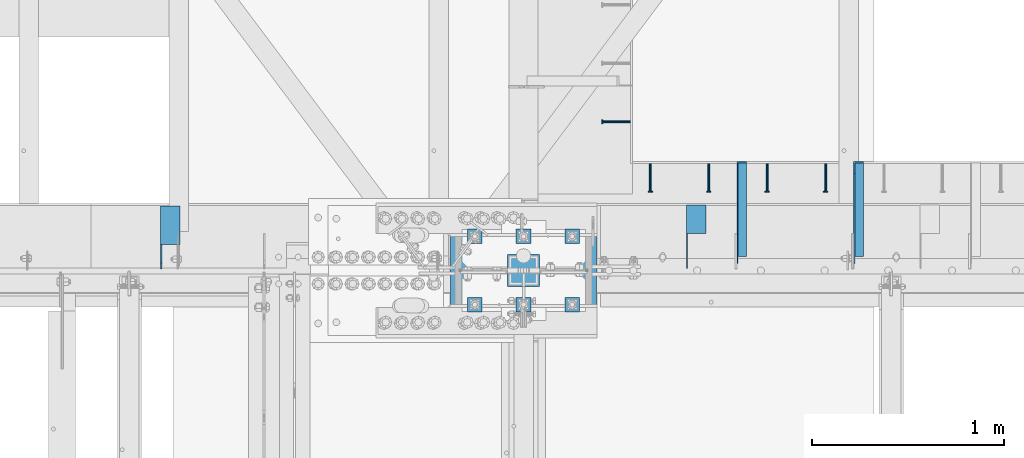
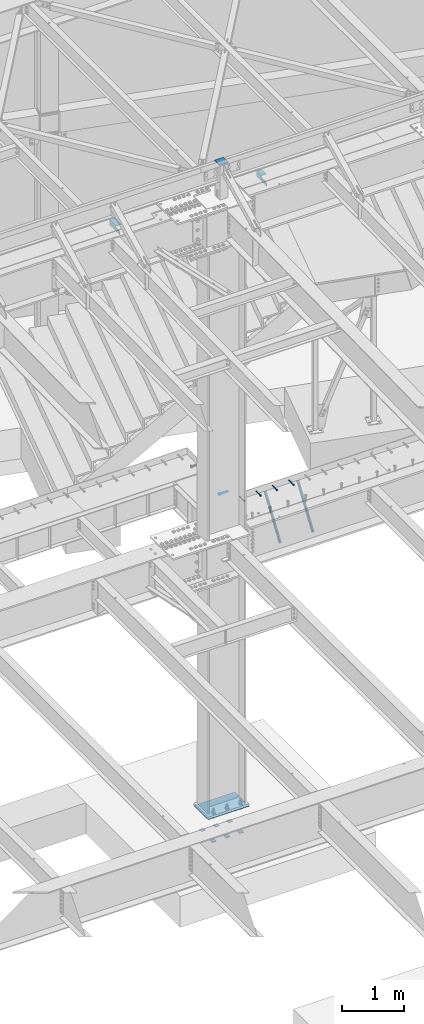
# One storey, part 1354 of 1763: 15 beams, 2 members, 10 elements without a shape of their own.
"""IFC2X3 building model written with IfcOpenShell, lengths in millimetres."""

from ifc_helpers import new_model, si_unit, frame, origin_with_axes, place, context, subcontext, project, spatial, faceted_brep, material, type_object, element, aggregate, save


model = new_model("IFC2X3")

# Units and contexts
model_context = context("Model", 3, precision=1e-05, world=origin_with_axes())
body_context = subcontext(model_context, "Body", "Model", "MODEL_VIEW")
ifc_project = project(units=[si_unit("LENGTHUNIT", "METRE", prefix="MILLI"), si_unit("AREAUNIT", "SQUARE_METRE"), si_unit("VOLUMEUNIT", "CUBIC_METRE"), si_unit("MASSUNIT", "GRAM", prefix="KILO"), si_unit("TIMEUNIT", "SECOND"), si_unit("PLANEANGLEUNIT", "RADIAN"), si_unit("SOLIDANGLEUNIT", "STERADIAN"), si_unit("THERMODYNAMICTEMPERATUREUNIT", "DEGREE_CELSIUS"), si_unit("LUMINOUSINTENSITYUNIT", "LUMEN")], contexts=[model_context])

# Site, building, storey
site_placement = place(None, origin_with_axes())
site = spatial("IfcSite", under=ifc_project, at=site_placement, CompositionType="ELEMENT")
building_placement = place(site_placement, origin_with_axes())
building = spatial("IfcBuilding", under=site, at=building_placement, Name="Undefined", CompositionType="ELEMENT")
storey_placement = place(building_placement, origin_with_axes())
storey = spatial("IfcBuildingStorey", under=building, at=storey_placement, Name="Undefined", CompositionType="ELEMENT", Elevation=0.0)

# Assembly, beam
assembly_1_placement = place(storey_placement, origin_with_axes())
assembly_1 = element("IfcElementAssembly", 1, at=assembly_1_placement, inside=storey, Name="HEADED STUD ANCHOR", AssemblyPlace="NOTDEFINED", PredefinedType="RIGID_FRAME")
ifc_material_1 = material(Name="STEEL/A108")
beam_type_1 = type_object("IfcBeamType", PredefinedType="NOTDEFINED")
beam_1_placement = place(assembly_1_placement, frame((-34391.0368708663, 52897.0884999161, 5264.15), z_axis=(0.0, 0.0, 1.0), x_axis=(-1.0, 0.0, 0.0)))
beam_1 = element("IfcBeam", 2, at=beam_1_placement, type_object=beam_type_1, material=ifc_material_1, Name="HEADED STUD ANCHOR", context=body_context, shape_type="Brep", body=[
    faceted_brep([(0.0, -3.1800000667572, 5.5), (0.0, -5.5, 3.1800000667572), (141.732000000002, -5.5, 3.1800000667572), (141.732000000002, -3.1800000667572, 5.5), (0.0, -6.34999999999491, 1.45519152283669e-11), (141.732000000002, -6.34999990463257, 0.0), (0.0, -5.5, -3.1800000667572), (141.732000000002, -5.5, -3.1800000667572), (0.0, -3.1800000667572, -5.5), (141.732000000002, -3.1800000667572, -5.5), (0.0, 0.0, -6.34999990463257), (141.732000000002, 0.0, -6.34999990463257), (0.0, 3.1800000667572, -5.5), (141.732000000002, 3.1800000667572, -5.5), (0.0, 5.5, -3.1800000667572), (141.732000000002, 5.5, -3.1800000667572), (0.0, 6.34999999999491, -2.91038304567337e-11), (141.732000000002, 6.34999990463257, 0.0), (0.0, 5.5, 3.1800000667572), (141.732000000002, 5.5, 3.1800000667572), (0.0, 3.1800000667572, 5.5), (141.732000000002, 3.1800000667572, 5.5), (0.0, 0.0, 6.34999990463257), (141.732000000002, 0.0, 6.34999990463257), (144.780000000001, -10.9899997711182, 6.34999990463257), (144.780000000001, -6.34000015258789, 10.9899997711182), (144.780000000001, -12.6999998092651, 0.0), (144.780000000001, -10.9899997711182, -6.34999990463257), (144.780000000001, -6.34000015258789, -10.9899997711182), (144.780000000001, 0.0, -12.6899995803833), (144.780000000001, 6.34000015258789, -10.9899997711182), (144.780000000001, 10.9899997711182, -6.34999990463257), (144.780000000001, 12.6999998092651, 0.0), (144.780000000001, 10.9899997711182, 6.34999990463257), (144.780000000001, 6.34000015258789, 10.9899997711182), (144.780000000001, 0.0, 12.6899995803833), (152.400000000001, -10.9899997711182, 6.34999990463257), (152.400000000001, -6.34000015258789, 10.9899997711182), (152.400000000001, -12.6999998092651, 0.0), (152.400000000001, -10.9899997711182, -6.34999990463257), (152.400000000001, -6.34000015258789, -10.9899997711182), (152.400000000001, 0.0, -12.6899995803833), (152.400000000001, 6.34000015258789, -10.9899997711182), (152.400000000001, 10.9899997711182, -6.34999990463257), (152.400000000001, 12.6999998092651, 0.0), (152.400000000001, 10.9899997711182, 6.34999990463257), (152.400000000001, 6.34000015258789, 10.9899997711182), (152.400000000001, 0.0, 12.6899995803833)], [[[0, 1, 2, 3]], [[1, 4, 5, 2]], [[4, 6, 7, 5]], [[6, 8, 9, 7]], [[8, 10, 11, 9]], [[10, 12, 13, 11]], [[12, 14, 15, 13]], [[14, 16, 17, 15]], [[16, 18, 19, 17]], [[18, 20, 21, 19]], [[20, 22, 23, 21]], [[22, 0, 3, 23]], [[22, 20, 18, 16, 14, 12, 10, 8, 6, 4, 1, 0]], [[3, 2, 24, 25]], [[2, 5, 26, 24]], [[5, 7, 27, 26]], [[7, 9, 28, 27]], [[9, 11, 29, 28]], [[11, 13, 30, 29]], [[13, 15, 31, 30]], [[15, 17, 32, 31]], [[17, 19, 33, 32]], [[19, 21, 34, 33]], [[21, 23, 35, 34]], [[23, 3, 25, 35]], [[25, 24, 36, 37]], [[24, 26, 38, 36]], [[26, 27, 39, 38]], [[27, 28, 40, 39]], [[28, 29, 41, 40]], [[29, 30, 42, 41]], [[30, 31, 43, 42]], [[31, 32, 44, 43]], [[32, 33, 45, 44]], [[33, 34, 46, 45]], [[34, 35, 47, 46]], [[35, 25, 37, 47]], [[38, 39, 40, 41, 42, 43, 44, 45, 46, 47, 37, 36]]]),
])
aggregate(assembly_1, [beam_1])

assembly_2_placement = place(storey_placement, origin_with_axes())
assembly_2 = element("IfcElementAssembly", 3, at=assembly_2_placement, inside=storey, Name="HEADED STUD ANCHOR", AssemblyPlace="NOTDEFINED", PredefinedType="RIGID_FRAME")
beam_2_placement = place(assembly_2_placement, frame((-33373.8466486983, 52679.6000091552, 5264.23140606069), z_axis=(0.0, 0.0, 1.0), x_axis=(0.0, -1.0, 0.0)))
beam_2 = element("IfcBeam", 4, at=beam_2_placement, type_object=beam_type_1, material=ifc_material_1, Name="HEADED STUD ANCHOR", context=body_context, shape_type="Brep", body=[
    faceted_brep([(0.0, -3.1800000667572, 5.5), (0.0, -5.5, 3.1800000667572), (141.732000000002, -5.5, 3.1800000667572), (141.732000000002, -3.1800000667572, 5.5), (0.0, -6.34999999999491, 1.45519152283669e-11), (141.732000000002, -6.34999990463257, 0.0), (0.0, -5.5, -3.1800000667572), (141.732000000002, -5.5, -3.1800000667572), (0.0, -3.1800000667572, -5.5), (141.732000000002, -3.1800000667572, -5.5), (0.0, 0.0, -6.34999990463257), (141.732000000002, 0.0, -6.34999990463257), (0.0, 3.1800000667572, -5.5), (141.732000000002, 3.1800000667572, -5.5), (0.0, 5.5, -3.1800000667572), (141.732000000002, 5.5, -3.1800000667572), (0.0, 6.34999999999491, -2.91038304567337e-11), (141.732000000002, 6.34999990463257, 0.0), (0.0, 5.5, 3.1800000667572), (141.732000000002, 5.5, 3.1800000667572), (0.0, 3.1800000667572, 5.5), (141.732000000002, 3.1800000667572, 5.5), (0.0, 0.0, 6.34999990463257), (141.732000000002, 0.0, 6.34999990463257), (144.780000000001, -10.9899997711182, 6.34999990463257), (144.780000000001, -6.34000015258789, 10.9899997711182), (144.780000000001, -12.6999998092651, 0.0), (144.780000000001, -10.9899997711182, -6.34999990463257), (144.780000000001, -6.34000015258789, -10.9899997711182), (144.780000000001, 0.0, -12.6899995803833), (144.780000000001, 6.34000015258789, -10.9899997711182), (144.780000000001, 10.9899997711182, -6.34999990463257), (144.780000000001, 12.6999998092651, 0.0), (144.780000000001, 10.9899997711182, 6.34999990463257), (144.780000000001, 6.34000015258789, 10.9899997711182), (144.780000000001, 0.0, 12.6899995803833), (152.400000000001, -10.9899997711182, 6.34999990463257), (152.400000000001, -6.34000015258789, 10.9899997711182), (152.400000000001, -12.6999998092651, 0.0), (152.400000000001, -10.9899997711182, -6.34999990463257), (152.400000000001, -6.34000015258789, -10.9899997711182), (152.400000000001, 0.0, -12.6899995803833), (152.400000000001, 6.34000015258789, -10.9899997711182), (152.400000000001, 10.9899997711182, -6.34999990463257), (152.400000000001, 12.6999998092651, 0.0), (152.400000000001, 10.9899997711182, 6.34999990463257), (152.400000000001, 6.34000015258789, 10.9899997711182), (152.400000000001, 0.0, 12.6899995803833)], [[[0, 1, 2, 3]], [[1, 4, 5, 2]], [[4, 6, 7, 5]], [[6, 8, 9, 7]], [[8, 10, 11, 9]], [[10, 12, 13, 11]], [[12, 14, 15, 13]], [[14, 16, 17, 15]], [[16, 18, 19, 17]], [[18, 20, 21, 19]], [[20, 22, 23, 21]], [[22, 0, 3, 23]], [[22, 20, 18, 16, 14, 12, 10, 8, 6, 4, 1, 0]], [[3, 2, 24, 25]], [[2, 5, 26, 24]], [[5, 7, 27, 26]], [[7, 9, 28, 27]], [[9, 11, 29, 28]], [[11, 13, 30, 29]], [[13, 15, 31, 30]], [[15, 17, 32, 31]], [[17, 19, 33, 32]], [[19, 21, 34, 33]], [[21, 23, 35, 34]], [[23, 3, 25, 35]], [[25, 24, 36, 37]], [[24, 26, 38, 36]], [[26, 27, 39, 38]], [[27, 28, 40, 39]], [[28, 29, 41, 40]], [[29, 30, 42, 41]], [[30, 31, 43, 42]], [[31, 32, 44, 43]], [[32, 33, 45, 44]], [[33, 34, 46, 45]], [[34, 35, 47, 46]], [[35, 25, 37, 47]], [[38, 39, 40, 41, 42, 43, 44, 45, 46, 47, 37, 36]]]),
])
aggregate(assembly_2, [beam_2])

assembly_3_placement = place(storey_placement, origin_with_axes())
assembly_3 = element("IfcElementAssembly", 5, at=assembly_3_placement, inside=storey, Name="HEADED STUD ANCHOR", AssemblyPlace="NOTDEFINED", PredefinedType="RIGID_FRAME")
beam_3_placement = place(assembly_3_placement, frame((-33678.6466486983, 52679.6000091552, 5264.23140606069), z_axis=(0.0, 0.0, 1.0), x_axis=(0.0, -1.0, 0.0)))
beam_3 = element("IfcBeam", 6, at=beam_3_placement, type_object=beam_type_1, material=ifc_material_1, Name="HEADED STUD ANCHOR", context=body_context, shape_type="Brep", body=[
    faceted_brep([(0.0, -3.1800000667572, 5.5), (0.0, -5.5, 3.1800000667572), (141.732000000002, -5.5, 3.1800000667572), (141.732000000002, -3.1800000667572, 5.5), (0.0, -6.34999999999491, 1.45519152283669e-11), (141.732000000002, -6.34999990463257, 0.0), (0.0, -5.5, -3.1800000667572), (141.732000000002, -5.5, -3.1800000667572), (0.0, -3.1800000667572, -5.5), (141.732000000002, -3.1800000667572, -5.5), (0.0, 0.0, -6.34999990463257), (141.732000000002, 0.0, -6.34999990463257), (0.0, 3.1800000667572, -5.5), (141.732000000002, 3.1800000667572, -5.5), (0.0, 5.5, -3.1800000667572), (141.732000000002, 5.5, -3.1800000667572), (0.0, 6.34999999999491, -2.91038304567337e-11), (141.732000000002, 6.34999990463257, 0.0), (0.0, 5.5, 3.1800000667572), (141.732000000002, 5.5, 3.1800000667572), (0.0, 3.1800000667572, 5.5), (141.732000000002, 3.1800000667572, 5.5), (0.0, 0.0, 6.34999990463257), (141.732000000002, 0.0, 6.34999990463257), (144.780000000001, -10.9899997711182, 6.34999990463257), (144.780000000001, -6.34000015258789, 10.9899997711182), (144.780000000001, -12.6999998092651, 0.0), (144.780000000001, -10.9899997711182, -6.34999990463257), (144.780000000001, -6.34000015258789, -10.9899997711182), (144.780000000001, 0.0, -12.6899995803833), (144.780000000001, 6.34000015258789, -10.9899997711182), (144.780000000001, 10.9899997711182, -6.34999990463257), (144.780000000001, 12.6999998092651, 0.0), (144.780000000001, 10.9899997711182, 6.34999990463257), (144.780000000001, 6.34000015258789, 10.9899997711182), (144.780000000001, 0.0, 12.6899995803833), (152.400000000001, -10.9899997711182, 6.34999990463257), (152.400000000001, -6.34000015258789, 10.9899997711182), (152.400000000001, -12.6999998092651, 0.0), (152.400000000001, -10.9899997711182, -6.34999990463257), (152.400000000001, -6.34000015258789, -10.9899997711182), (152.400000000001, 0.0, -12.6899995803833), (152.400000000001, 6.34000015258789, -10.9899997711182), (152.400000000001, 10.9899997711182, -6.34999990463257), (152.400000000001, 12.6999998092651, 0.0), (152.400000000001, 10.9899997711182, 6.34999990463257), (152.400000000001, 6.34000015258789, 10.9899997711182), (152.400000000001, 0.0, 12.6899995803833)], [[[0, 1, 2, 3]], [[1, 4, 5, 2]], [[4, 6, 7, 5]], [[6, 8, 9, 7]], [[8, 10, 11, 9]], [[10, 12, 13, 11]], [[12, 14, 15, 13]], [[14, 16, 17, 15]], [[16, 18, 19, 17]], [[18, 20, 21, 19]], [[20, 22, 23, 21]], [[22, 0, 3, 23]], [[22, 20, 18, 16, 14, 12, 10, 8, 6, 4, 1, 0]], [[3, 2, 24, 25]], [[2, 5, 26, 24]], [[5, 7, 27, 26]], [[7, 9, 28, 27]], [[9, 11, 29, 28]], [[11, 13, 30, 29]], [[13, 15, 31, 30]], [[15, 17, 32, 31]], [[17, 19, 33, 32]], [[19, 21, 34, 33]], [[21, 23, 35, 34]], [[23, 3, 25, 35]], [[25, 24, 36, 37]], [[24, 26, 38, 36]], [[26, 27, 39, 38]], [[27, 28, 40, 39]], [[28, 29, 41, 40]], [[29, 30, 42, 41]], [[30, 31, 43, 42]], [[31, 32, 44, 43]], [[32, 33, 45, 44]], [[33, 34, 46, 45]], [[34, 35, 47, 46]], [[35, 25, 37, 47]], [[38, 39, 40, 41, 42, 43, 44, 45, 46, 47, 37, 36]]]),
])
aggregate(assembly_3, [beam_3])

assembly_4_placement = place(storey_placement, origin_with_axes())
assembly_4 = element("IfcElementAssembly", 7, at=assembly_4_placement, inside=storey, Name="HEADED STUD ANCHOR", AssemblyPlace="NOTDEFINED", PredefinedType="RIGID_FRAME")
beam_4_placement = place(assembly_4_placement, frame((-33983.4466486983, 52679.6000091552, 5264.23140606069), z_axis=(0.0, 0.0, 1.0), x_axis=(0.0, -1.0, 0.0)))
beam_4 = element("IfcBeam", 8, at=beam_4_placement, type_object=beam_type_1, material=ifc_material_1, Name="HEADED STUD ANCHOR", context=body_context, shape_type="Brep", body=[
    faceted_brep([(0.0, -3.1800000667572, 5.5), (0.0, -5.5, 3.1800000667572), (141.732000000002, -5.5, 3.1800000667572), (141.732000000002, -3.1800000667572, 5.5), (0.0, -6.34999999999491, 1.45519152283669e-11), (141.732000000002, -6.34999990463257, 0.0), (0.0, -5.5, -3.1800000667572), (141.732000000002, -5.5, -3.1800000667572), (0.0, -3.1800000667572, -5.5), (141.732000000002, -3.1800000667572, -5.5), (0.0, 0.0, -6.34999990463257), (141.732000000002, 0.0, -6.34999990463257), (0.0, 3.1800000667572, -5.5), (141.732000000002, 3.1800000667572, -5.5), (0.0, 5.5, -3.1800000667572), (141.732000000002, 5.5, -3.1800000667572), (0.0, 6.34999999999491, -2.91038304567337e-11), (141.732000000002, 6.34999990463257, 0.0), (0.0, 5.5, 3.1800000667572), (141.732000000002, 5.5, 3.1800000667572), (0.0, 3.1800000667572, 5.5), (141.732000000002, 3.1800000667572, 5.5), (0.0, 0.0, 6.34999990463257), (141.732000000002, 0.0, 6.34999990463257), (144.780000000001, -10.9899997711182, 6.34999990463257), (144.780000000001, -6.34000015258789, 10.9899997711182), (144.780000000001, -12.6999998092651, 0.0), (144.780000000001, -10.9899997711182, -6.34999990463257), (144.780000000001, -6.34000015258789, -10.9899997711182), (144.780000000001, 0.0, -12.6899995803833), (144.780000000001, 6.34000015258789, -10.9899997711182), (144.780000000001, 10.9899997711182, -6.34999990463257), (144.780000000001, 12.6999998092651, 0.0), (144.780000000001, 10.9899997711182, 6.34999990463257), (144.780000000001, 6.34000015258789, 10.9899997711182), (144.780000000001, 0.0, 12.6899995803833), (152.400000000001, -10.9899997711182, 6.34999990463257), (152.400000000001, -6.34000015258789, 10.9899997711182), (152.400000000001, -12.6999998092651, 0.0), (152.400000000001, -10.9899997711182, -6.34999990463257), (152.400000000001, -6.34000015258789, -10.9899997711182), (152.400000000001, 0.0, -12.6899995803833), (152.400000000001, 6.34000015258789, -10.9899997711182), (152.400000000001, 10.9899997711182, -6.34999990463257), (152.400000000001, 12.6999998092651, 0.0), (152.400000000001, 10.9899997711182, 6.34999990463257), (152.400000000001, 6.34000015258789, 10.9899997711182), (152.400000000001, 0.0, 12.6899995803833)], [[[0, 1, 2, 3]], [[1, 4, 5, 2]], [[4, 6, 7, 5]], [[6, 8, 9, 7]], [[8, 10, 11, 9]], [[10, 12, 13, 11]], [[12, 14, 15, 13]], [[14, 16, 17, 15]], [[16, 18, 19, 17]], [[18, 20, 21, 19]], [[20, 22, 23, 21]], [[22, 0, 3, 23]], [[22, 20, 18, 16, 14, 12, 10, 8, 6, 4, 1, 0]], [[3, 2, 24, 25]], [[2, 5, 26, 24]], [[5, 7, 27, 26]], [[7, 9, 28, 27]], [[9, 11, 29, 28]], [[11, 13, 30, 29]], [[13, 15, 31, 30]], [[15, 17, 32, 31]], [[17, 19, 33, 32]], [[19, 21, 34, 33]], [[21, 23, 35, 34]], [[23, 3, 25, 35]], [[25, 24, 36, 37]], [[24, 26, 38, 36]], [[26, 27, 39, 38]], [[27, 28, 40, 39]], [[28, 29, 41, 40]], [[29, 30, 42, 41]], [[30, 31, 43, 42]], [[31, 32, 44, 43]], [[32, 33, 45, 44]], [[33, 34, 46, 45]], [[34, 35, 47, 46]], [[35, 25, 37, 47]], [[38, 39, 40, 41, 42, 43, 44, 45, 46, 47, 37, 36]]]),
])
aggregate(assembly_4, [beam_4])

assembly_5_placement = place(storey_placement, origin_with_axes())
assembly_5 = element("IfcElementAssembly", 9, at=assembly_5_placement, inside=storey, Name="HEADED STUD ANCHOR", AssemblyPlace="NOTDEFINED", PredefinedType="RIGID_FRAME")
beam_5_placement = place(assembly_5_placement, frame((-34288.2466486983, 52679.6000091552, 5264.23140606069), z_axis=(0.0, 0.0, 1.0), x_axis=(0.0, -1.0, 0.0)))
beam_5 = element("IfcBeam", 10, at=beam_5_placement, type_object=beam_type_1, material=ifc_material_1, Name="HEADED STUD ANCHOR", context=body_context, shape_type="Brep", body=[
    faceted_brep([(0.0, -3.1800000667572, 5.5), (0.0, -5.5, 3.1800000667572), (141.732000000002, -5.5, 3.1800000667572), (141.732000000002, -3.1800000667572, 5.5), (0.0, -6.34999999999491, 1.45519152283669e-11), (141.732000000002, -6.34999990463257, 0.0), (0.0, -5.5, -3.1800000667572), (141.732000000002, -5.5, -3.1800000667572), (0.0, -3.1800000667572, -5.5), (141.732000000002, -3.1800000667572, -5.5), (0.0, 0.0, -6.34999990463257), (141.732000000002, 0.0, -6.34999990463257), (0.0, 3.1800000667572, -5.5), (141.732000000002, 3.1800000667572, -5.5), (0.0, 5.5, -3.1800000667572), (141.732000000002, 5.5, -3.1800000667572), (0.0, 6.34999999999491, -2.91038304567337e-11), (141.732000000002, 6.34999990463257, 0.0), (0.0, 5.5, 3.1800000667572), (141.732000000002, 5.5, 3.1800000667572), (0.0, 3.1800000667572, 5.5), (141.732000000002, 3.1800000667572, 5.5), (0.0, 0.0, 6.34999990463257), (141.732000000002, 0.0, 6.34999990463257), (144.780000000001, -10.9899997711182, 6.34999990463257), (144.780000000001, -6.34000015258789, 10.9899997711182), (144.780000000001, -12.6999998092651, 0.0), (144.780000000001, -10.9899997711182, -6.34999990463257), (144.780000000001, -6.34000015258789, -10.9899997711182), (144.780000000001, 0.0, -12.6899995803833), (144.780000000001, 6.34000015258789, -10.9899997711182), (144.780000000001, 10.9899997711182, -6.34999990463257), (144.780000000001, 12.6999998092651, 0.0), (144.780000000001, 10.9899997711182, 6.34999990463257), (144.780000000001, 6.34000015258789, 10.9899997711182), (144.780000000001, 0.0, 12.6899995803833), (152.400000000001, -10.9899997711182, 6.34999990463257), (152.400000000001, -6.34000015258789, 10.9899997711182), (152.400000000001, -12.6999998092651, 0.0), (152.400000000001, -10.9899997711182, -6.34999990463257), (152.400000000001, -6.34000015258789, -10.9899997711182), (152.400000000001, 0.0, -12.6899995803833), (152.400000000001, 6.34000015258789, -10.9899997711182), (152.400000000001, 10.9899997711182, -6.34999990463257), (152.400000000001, 12.6999998092651, 0.0), (152.400000000001, 10.9899997711182, 6.34999990463257), (152.400000000001, 6.34000015258789, 10.9899997711182), (152.400000000001, 0.0, 12.6899995803833)], [[[0, 1, 2, 3]], [[1, 4, 5, 2]], [[4, 6, 7, 5]], [[6, 8, 9, 7]], [[8, 10, 11, 9]], [[10, 12, 13, 11]], [[12, 14, 15, 13]], [[14, 16, 17, 15]], [[16, 18, 19, 17]], [[18, 20, 21, 19]], [[20, 22, 23, 21]], [[22, 0, 3, 23]], [[22, 20, 18, 16, 14, 12, 10, 8, 6, 4, 1, 0]], [[3, 2, 24, 25]], [[2, 5, 26, 24]], [[5, 7, 27, 26]], [[7, 9, 28, 27]], [[9, 11, 29, 28]], [[11, 13, 30, 29]], [[13, 15, 31, 30]], [[15, 17, 32, 31]], [[17, 19, 33, 32]], [[19, 21, 34, 33]], [[21, 23, 35, 34]], [[23, 3, 25, 35]], [[25, 24, 36, 37]], [[24, 26, 38, 36]], [[26, 27, 39, 38]], [[27, 28, 40, 39]], [[28, 29, 41, 40]], [[29, 30, 42, 41]], [[30, 31, 43, 42]], [[31, 32, 44, 43]], [[32, 33, 45, 44]], [[33, 34, 46, 45]], [[34, 35, 47, 46]], [[35, 25, 37, 47]], [[38, 39, 40, 41, 42, 43, 44, 45, 46, 47, 37, 36]]]),
])
aggregate(assembly_5, [beam_5])

# Assembly, members
assembly_6_placement = place(storey_placement, origin_with_axes())
assembly_6 = element("IfcElementAssembly", 11, at=assembly_6_placement, inside=storey, Name="BEAM", AssemblyPlace="NOTDEFINED", PredefinedType="RIGID_FRAME")
ifc_material_2 = material(Name="STEEL/A36")
member_type = type_object("IfcMemberType", Name="L2X2X1/4", PredefinedType="NOTDEFINED")
member_1_placement = place(assembly_6_placement, frame((-33201.8370109278, 52177.7789126344, 4484.66874800095), z_axis=(0.0, -0.827940419190063, 0.560816068128742), x_axis=(0.0, 0.560816068128741, 0.827940419190064)))
member_1 = element("IfcMember", 12, at=member_1_placement, type_object=member_type, material=ifc_material_2, Name="ANGLE", ObjectType="L2X2X1/4", context=body_context, shape_type="Brep", body=[
    faceted_brep([(-1.45519152283669e-11, 25.4000000000015, -25.3999999999869), (1.45519152283669e-11, 25.4000000000015, 25.3999999999796), (839.899233991324, 25.4000000000015, 25.3999999994412), (874.309265921926, 25.4000000000015, -25.4000000006854), (1.45519152283669e-11, 19.0499999999993, 25.3999999999796), (839.899233991324, 19.0499999999993, 25.3999999994412), (-7.27595761418343e-12, 19.0499999999993, -19.0499999999956), (870.0080119306, 19.0499999999993, -19.0500000006723), (-7.27595761418343e-12, -25.4000000000015, -19.0499999999956), (870.0080119306, -25.4000000000015, -19.0500000006723), (-1.45519152283669e-11, -25.4000000000015, -25.3999999999869), (874.309265921926, -25.4000000000015, -25.4000000006854)], [[[0, 1, 2, 3]], [[1, 4, 5, 2]], [[4, 6, 7, 5]], [[6, 8, 9, 7]], [[8, 10, 11, 9]], [[10, 0, 3, 11]], [[5, 7, 9, 11, 3, 2]], [[10, 8, 6, 4, 1, 0]]]),
])
member_2_placement = place(assembly_6_placement, frame((-33811.4375109278, 52177.7789125302, 4484.6687480715), z_axis=(0.0, -0.827940419190063, 0.560816068128742), x_axis=(0.0, 0.560816068128741, 0.827940419190064)))
member_2 = element("IfcMember", 13, at=member_2_placement, type_object=member_type, material=ifc_material_2, Name="ANGLE", ObjectType="L2X2X1/4", context=body_context, shape_type="Brep", body=[
    faceted_brep([(-1.45519152283669e-11, 25.4000000000015, -25.3999999999869), (1.45519152283669e-11, 25.4000000000015, 25.3999999999796), (839.899233991324, 25.4000000000015, 25.3999999994412), (874.309265921926, 25.4000000000015, -25.4000000006854), (1.45519152283669e-11, 19.0499999999993, 25.3999999999796), (839.899233991324, 19.0499999999993, 25.3999999994412), (-7.27595761418343e-12, 19.0499999999993, -19.0499999999956), (870.0080119306, 19.0499999999993, -19.0500000006723), (-7.27595761418343e-12, -25.4000000000015, -19.0499999999956), (870.0080119306, -25.4000000000015, -19.0500000006723), (-1.45519152283669e-11, -25.4000000000015, -25.3999999999869), (874.309265921926, -25.4000000000015, -25.4000000006854)], [[[0, 1, 2, 3]], [[1, 4, 5, 2]], [[4, 6, 7, 5]], [[6, 8, 9, 7]], [[8, 10, 11, 9]], [[10, 0, 3, 11]], [[5, 7, 9, 11, 3, 2]], [[10, 8, 6, 4, 1, 0]]]),
])
aggregate(assembly_6, [member_1, member_2])

# Assembly, beam
assembly_7_placement = place(storey_placement, origin_with_axes())
assembly_7 = element("IfcElementAssembly", 14, at=assembly_7_placement, inside=storey, Name="BEAM", AssemblyPlace="NOTDEFINED", PredefinedType="RIGID_FRAME")
beam_type_2 = type_object("IfcBeamType", Name="L4X4X1/4", PredefinedType="NOTDEFINED")
beam_6_placement = place(assembly_7_placement, frame((-34049.7247736983, 52462.1124819023, 11696.6999917654), z_axis=(0.0, 0.0, -1.0), x_axis=(0.0, -1.0, 0.0)))
beam_6 = element("IfcBeam", 15, at=beam_6_placement, type_object=beam_type_2, material=ifc_material_2, Name="BRACE", ObjectType="L4X4X1/4", context=body_context, shape_type="Brep", body=[
    faceted_brep([(148.43173432786, 44.4500000000007, -44.4500000000007), (148.431790430077, -50.7999999999993, -44.4500000000007), (148.431790785675, -50.7999999999993, -50.7999999999993), (148.43173094331, 50.7999999999993, -50.7999999999993), (148.431728809323, 50.7999999999993, -12.6999970794623), (148.431732549492, 44.4500000000007, -12.6999970794623), (299.243731689443, 50.7999999999993, -12.7000043904281), (299.243731689443, 44.4499999999971, -12.7000043904281), (2.11002770811319e-10, -50.8000000000357, -50.799999999952), (1.96450855582952e-10, -50.8000000000338, -44.4499999999534), (-2.18278728425503e-11, 44.4500000000007, -44.450000000048), (-1.81898940354586e-10, 44.4500000000371, 50.7999999999374), (-1.96450855582952e-10, 50.8000000000393, 50.7999999999374), (-3.63797880709171e-11, 50.8000000000011, -50.8000000000538), (330.993731689443, 44.4500000000007, 50.7999999999993), (330.993731689443, 50.7999999999993, 50.7999999999993), (330.993731689443, 44.4500000000007, 19.050000000012), (330.993731689443, 50.7999999999993, 19.050000000012)], [[[0, 1, 2, 3, 4, 5]], [[5, 4, 6, 7]], [[8, 9, 10, 11, 12, 13]], [[12, 11, 14, 15]], [[15, 14, 16, 17]], [[16, 7, 6, 17]], [[4, 3, 13, 12, 15, 17, 6]], [[8, 13, 3, 2]], [[9, 8, 2, 1]], [[10, 9, 1, 0]], [[14, 11, 10, 0, 5, 7, 16]]]),
])
aggregate(assembly_7, [beam_6])

assembly_8_placement = place(storey_placement, origin_with_axes())
assembly_8 = element("IfcElementAssembly", 16, at=assembly_8_placement, inside=storey, Name="BEAM", AssemblyPlace="NOTDEFINED", PredefinedType="RIGID_FRAME")
beam_7_placement = place(assembly_8_placement, frame((-36792.9247736984, 52457.3499819023, 11696.6999917654), z_axis=(0.0, 0.0, -1.0), x_axis=(0.0, -1.0, 0.0)))
beam_7 = element("IfcBeam", 17, at=beam_7_placement, type_object=beam_type_2, material=ifc_material_2, Name="BRACE", ObjectType="L4X4X1/4", context=body_context, shape_type="Brep", body=[
    faceted_brep([(328.61248169496, 44.4499999999971, 11.1124990719582), (296.86248169496, 44.4499999999971, -20.6375000119442), (296.86248169496, 50.8000000000029, -20.6375000119442), (328.612481689444, 50.8000000000029, 11.1124990719582), (1.96450855582952e-10, -50.8000000000338, -44.4499999999534), (2.11002770811319e-10, -50.8000000000357, -50.799999999952), (201.612481689481, -50.8000000000029, -50.7999999999993), (201.612481048192, -50.8000000000029, -44.4500000000007), (-3.63797880709171e-11, 50.8000000000011, -50.8000000000538), (201.612481689481, 50.8000000000029, -50.7999999999993), (201.612481048192, 44.4499999999971, -44.4500000000007), (201.612478643146, 50.8000000000029, -20.637499618555), (201.612478643146, 44.4499999999971, -20.637499618555), (-2.18278728425503e-11, 44.4500000000007, -44.450000000048), (-1.81898940354586e-10, 44.4500000000371, 50.7999999999374), (-1.96450855582952e-10, 50.8000000000393, 50.7999999999374), (328.612481689444, 44.4499999999971, 50.7999999999993), (328.612481689444, 50.8000000000029, 50.7999999999993)], [[[0, 1, 2, 3]], [[4, 5, 6, 7]], [[5, 8, 9, 6]], [[10, 7, 6, 9, 11, 12]], [[13, 4, 7, 10]], [[5, 4, 13, 14, 15, 8]], [[15, 14, 16, 17]], [[17, 16, 0, 3]], [[11, 9, 8, 15, 17, 3, 2]], [[12, 11, 2, 1]], [[16, 14, 13, 10, 12, 1, 0]]]),
])
aggregate(assembly_8, [beam_7])

# Assembly, beams
assembly_9_placement = place(storey_placement, origin_with_axes())
assembly_9 = element("IfcElementAssembly", 18, at=assembly_9_placement, inside=storey, Name="TEMPLATE", AssemblyPlace="NOTDEFINED", PredefinedType="RIGID_FRAME")
beam_type_3 = type_object("IfcBeamType", PredefinedType="NOTDEFINED")
beam_8_placement = place(assembly_9_placement, frame((-34657.7372736984, 51943.0, -758.824999999997), z_axis=(0.0, 1.0, 0.0), x_axis=(-1.0, 0.0, 0.0)))
beam_8 = element("IfcBeam", 19, at=beam_8_placement, type_object=beam_type_3, material=ifc_material_2, Name="WASHER PLATE", context=body_context, shape_type="Brep", body=[
    faceted_brep([(0.0, 3.17500000000018, -38.0999999999985), (0.0, 3.17500000000018, 38.0999999999985), (76.1999999999971, 3.17499999999995, 38.0999999999985), (76.1999999999971, 3.17499999999995, -38.0999999999985), (0.0, -3.17500000000018, 38.0999999999985), (76.1999999999971, -3.17499999999995, 38.0999999999985), (0.0, -3.17500000000018, -38.0999999999985), (76.1999999999971, -3.17499999999995, -38.0999999999985)], [[[0, 1, 2, 3]], [[1, 4, 5, 2]], [[4, 6, 7, 5]], [[6, 0, 3, 7]], [[5, 7, 3, 2]], [[6, 4, 1, 0]]]),
])
beam_9_placement = place(assembly_9_placement, frame((-34657.7372736984, 52298.6, -758.824999999997), z_axis=(0.0, 1.0, 0.0), x_axis=(-1.0, 0.0, 0.0)))
beam_9 = element("IfcBeam", 20, at=beam_9_placement, type_object=beam_type_3, material=ifc_material_2, Name="WASHER PLATE", context=body_context, shape_type="Brep", body=[
    faceted_brep([(0.0, 3.17500000000018, -38.0999999999985), (0.0, 3.17500000000018, 38.0999999999985), (76.1999999999971, 3.17499999999995, 38.0999999999985), (76.1999999999971, 3.17499999999995, -38.0999999999985), (0.0, -3.17500000000018, 38.0999999999985), (76.1999999999971, -3.17499999999995, 38.0999999999985), (0.0, -3.17500000000018, -38.0999999999985), (76.1999999999971, -3.17499999999995, -38.0999999999985)], [[[0, 1, 2, 3]], [[1, 4, 5, 2]], [[4, 6, 7, 5]], [[6, 0, 3, 7]], [[5, 7, 3, 2]], [[6, 4, 1, 0]]]),
])
beam_10_placement = place(assembly_9_placement, frame((-34911.7372736984, 51943.0, -758.824999999997), z_axis=(0.0, 1.0, 0.0), x_axis=(-1.0, 0.0, 0.0)))
beam_10 = element("IfcBeam", 21, at=beam_10_placement, type_object=beam_type_3, material=ifc_material_2, Name="WASHER PLATE", context=body_context, shape_type="Brep", body=[
    faceted_brep([(0.0, 3.17500000000018, -38.0999999999985), (0.0, 3.17500000000018, 38.0999999999985), (76.1999999999971, 3.17499999999995, 38.0999999999985), (76.1999999999971, 3.17499999999995, -38.0999999999985), (0.0, -3.17500000000018, 38.0999999999985), (76.1999999999971, -3.17499999999995, 38.0999999999985), (0.0, -3.17500000000018, -38.0999999999985), (76.1999999999971, -3.17499999999995, -38.0999999999985)], [[[0, 1, 2, 3]], [[1, 4, 5, 2]], [[4, 6, 7, 5]], [[6, 0, 3, 7]], [[5, 7, 3, 2]], [[6, 4, 1, 0]]]),
])
beam_11_placement = place(assembly_9_placement, frame((-34911.7372736984, 52298.6, -758.824999999997), z_axis=(0.0, 1.0, 0.0), x_axis=(-1.0, 0.0, 0.0)))
beam_11 = element("IfcBeam", 22, at=beam_11_placement, type_object=beam_type_3, material=ifc_material_2, Name="WASHER PLATE", context=body_context, shape_type="Brep", body=[
    faceted_brep([(0.0, 3.17500000000018, -38.0999999999985), (0.0, 3.17500000000018, 38.0999999999985), (76.1999999999971, 3.17499999999995, 38.0999999999985), (76.1999999999971, 3.17499999999995, -38.0999999999985), (0.0, -3.17500000000018, 38.0999999999985), (76.1999999999971, -3.17499999999995, 38.0999999999985), (0.0, -3.17500000000018, -38.0999999999985), (76.1999999999971, -3.17499999999995, -38.0999999999985)], [[[0, 1, 2, 3]], [[1, 4, 5, 2]], [[4, 6, 7, 5]], [[6, 0, 3, 7]], [[5, 7, 3, 2]], [[6, 4, 1, 0]]]),
])
beam_12_placement = place(assembly_9_placement, frame((-35165.7372736984, 51943.0, -758.824999999997), z_axis=(0.0, 1.0, 0.0), x_axis=(-1.0, 0.0, 0.0)))
beam_12 = element("IfcBeam", 23, at=beam_12_placement, type_object=beam_type_3, material=ifc_material_2, Name="WASHER PLATE", context=body_context, shape_type="Brep", body=[
    faceted_brep([(0.0, 3.17500000000018, -38.0999999999985), (0.0, 3.17500000000018, 38.0999999999985), (76.1999999999971, 3.17499999999995, 38.0999999999985), (76.1999999999971, 3.17499999999995, -38.0999999999985), (0.0, -3.17500000000018, 38.0999999999985), (76.1999999999971, -3.17499999999995, 38.0999999999985), (0.0, -3.17500000000018, -38.0999999999985), (76.1999999999971, -3.17499999999995, -38.0999999999985)], [[[0, 1, 2, 3]], [[1, 4, 5, 2]], [[4, 6, 7, 5]], [[6, 0, 3, 7]], [[5, 7, 3, 2]], [[6, 4, 1, 0]]]),
])
beam_13_placement = place(assembly_9_placement, frame((-35165.7372736984, 52298.6, -758.824999999997), z_axis=(0.0, 1.0, 0.0), x_axis=(-1.0, 0.0, 0.0)))
beam_13 = element("IfcBeam", 24, at=beam_13_placement, type_object=beam_type_3, material=ifc_material_2, Name="WASHER PLATE", context=body_context, shape_type="Brep", body=[
    faceted_brep([(0.0, 3.17500000000018, -38.0999999999985), (0.0, 3.17500000000018, 38.0999999999985), (76.1999999999971, 3.17499999999995, 38.0999999999985), (76.1999999999971, 3.17499999999995, -38.0999999999985), (0.0, -3.17500000000018, 38.0999999999985), (76.1999999999971, -3.17499999999995, 38.0999999999985), (0.0, -3.17500000000018, -38.0999999999985), (76.1999999999971, -3.17499999999995, -38.0999999999985)], [[[0, 1, 2, 3]], [[1, 4, 5, 2]], [[4, 6, 7, 5]], [[6, 0, 3, 7]], [[5, 7, 3, 2]], [[6, 4, 1, 0]]]),
])

# Assembly, beam
assembly_10_placement = place(storey_placement, origin_with_axes())
assembly_10 = element("IfcElementAssembly", 25, at=assembly_10_placement, inside=storey, Name="COLUMN", AssemblyPlace="NOTDEFINED", PredefinedType="RIGID_FRAME")
beam_type_4 = type_object("IfcBeamType", PredefinedType="NOTDEFINED")
beam_14_placement = place(assembly_10_placement, frame((-34949.837273697, 52038.250000001, 12439.65), z_axis=(1.0, 0.0, 0.0), x_axis=(0.0, 1.0, 0.0)))
beam_14 = element("IfcBeam", 26, at=beam_14_placement, type_object=beam_type_4, material=ifc_material_2, Name="PLATE", context=body_context, shape_type="Brep", body=[
    faceted_brep([(0.0, 6.35000000000036, -82.5499999999993), (0.0, 6.35000000000036, 82.5499999999993), (165.099999999991, 6.35000000000036, 82.5499999999993), (165.099999999991, 6.35000000000036, -82.5499999999993), (0.0, -6.35000000000036, 82.5499999999993), (165.099999999991, -6.35000000000036, 82.5499999999993), (0.0, -6.35000000000036, -82.5499999999993), (165.099999999991, -6.35000000000036, -82.5499999999993)], [[[0, 1, 2, 3]], [[1, 4, 5, 2]], [[4, 6, 7, 5]], [[6, 0, 3, 7]], [[5, 7, 3, 2]], [[6, 4, 1, 0]]]),
])
aggregate(assembly_10, [beam_14])

# Beam
beam_type_5 = type_object("IfcBeamType", PredefinedType="NOTDEFINED")
beam_15_placement = place(assembly_9_placement, frame((-34568.8372736984, 52120.8, -263.524999999997), z_axis=(0.0, -1.0, 0.0), x_axis=(-1.0, 0.0, 0.0)))
beam_15 = element("IfcBeam", 27, at=beam_15_placement, type_object=beam_type_5, material=ifc_material_2, Name="TEMPLATE", context=body_context, shape_type="Brep", body=[
    faceted_brep([(0.0, 3.17500000000001, -228.599999999999), (0.0, 3.17500000000001, 228.599999999999), (762.0, 3.17500000000001, 228.599999999999), (762.0, 3.17500000000001, -228.599999999999), (0.0, -3.17500000000001, 228.599999999999), (762.0, -3.17500000000001, 228.599999999999), (0.0, -3.17500000000001, -228.599999999999), (762.0, -3.17500000000001, -228.599999999999)], [[[0, 1, 2, 3]], [[1, 4, 5, 2]], [[4, 6, 7, 5]], [[6, 0, 3, 7]], [[5, 7, 3, 2]], [[6, 4, 1, 0]]]),
])

aggregate(assembly_9, [beam_8, beam_9, beam_10, beam_11, beam_12, beam_13, beam_15])

save(model, "model.ifc")
